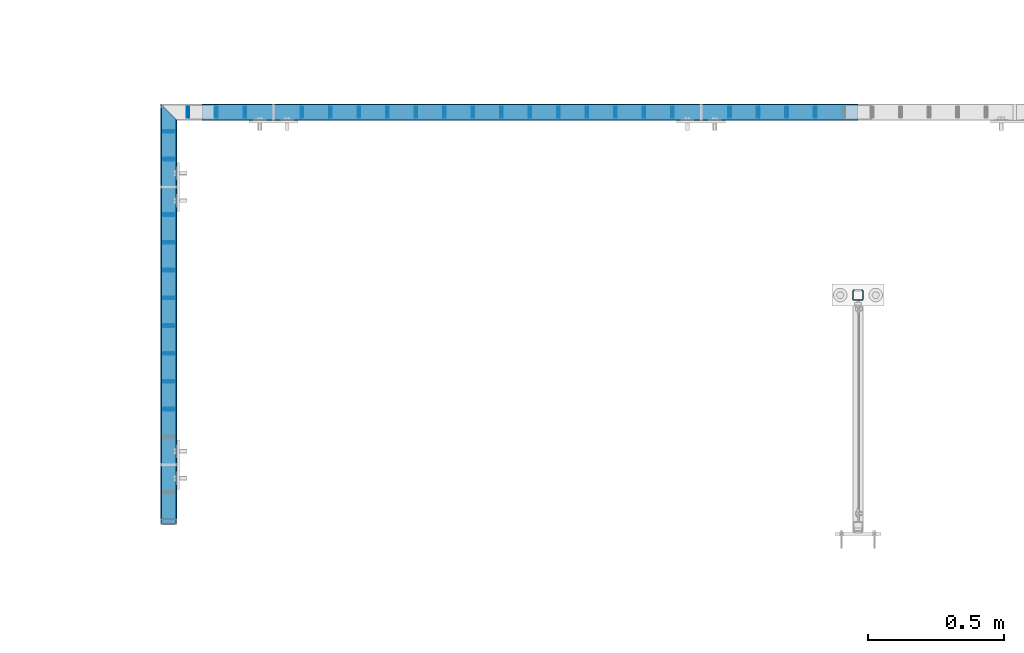
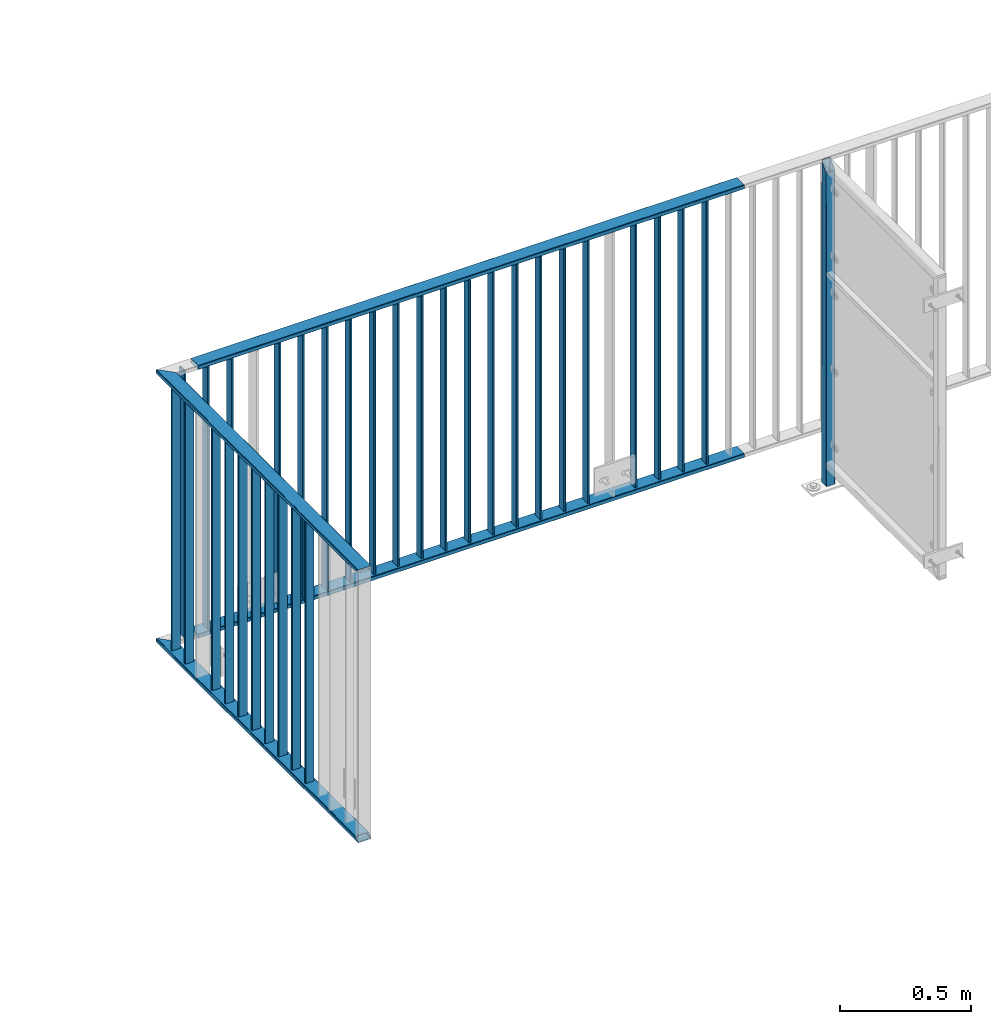
# One storey, part 34 of 156: 36 beams, 3 elements without a shape of their own.
"""IFC2X3 building model written with IfcOpenShell, lengths in millimetres."""

from ifc_helpers import new_model, si_unit, frame, origin_with_axes, origin_2d_with_axis, place, context, subcontext, project, spatial, hollow_rectangle, extrude, clip, halfspace, material, type_object, element, aggregate, save


model = new_model("IFC2X3")

# Units and contexts
model_context = context("Model", 3, precision=1e-05, world=origin_with_axes())
body_context = subcontext(model_context, "Body", "Model", "MODEL_VIEW")
ifc_project = project(units=[si_unit("LENGTHUNIT", "METRE", prefix="MILLI"), si_unit("AREAUNIT", "SQUARE_METRE"), si_unit("VOLUMEUNIT", "CUBIC_METRE"), si_unit("MASSUNIT", "GRAM", prefix="KILO"), si_unit("TIMEUNIT", "SECOND"), si_unit("PLANEANGLEUNIT", "RADIAN"), si_unit("SOLIDANGLEUNIT", "STERADIAN"), si_unit("THERMODYNAMICTEMPERATUREUNIT", "DEGREE_CELSIUS"), si_unit("LUMINOUSINTENSITYUNIT", "LUMEN")], contexts=[model_context])

# Site, building, storey
site_placement = place(None, origin_with_axes())
site = spatial("IfcSite", under=ifc_project, at=site_placement, CompositionType="ELEMENT")
building_placement = place(site_placement, origin_with_axes())
building = spatial("IfcBuilding", under=site, at=building_placement, Name="Undefined", CompositionType="ELEMENT")
storey_placement = place(building_placement, origin_with_axes())
storey = spatial("IfcBuildingStorey", under=building, at=storey_placement, Name="Undefined", CompositionType="ELEMENT", Elevation=0.0)

# Assembly, beam
assembly_1_placement = place(storey_placement, origin_with_axes())
assembly_1 = element("IfcElementAssembly", 1, at=assembly_1_placement, inside=storey, AssemblyPlace="NOTDEFINED", PredefinedType="RIGID_FRAME")
ifc_material = material(Name="STEEL/S235JR")
beam_type_1 = type_object("IfcBeamType", Name="K60/20/2", PredefinedType="NOTDEFINED")
beam_1_placement = place(assembly_1_placement, frame((43599.9526043701, 21657.990447998, 2740.0), z_axis=(0.0, -1.0, 0.0), x_axis=(-1.0, 0.0, 0.0)))
beam_1 = element("IfcBeam", 2, at=beam_1_placement, type_object=beam_type_1, material=ifc_material, ObjectType="K60/20/2", context=body_context, shape_type="SweptSolid", body=[
    extrude(hollow_rectangle(XDim=20.0, YDim=60.0, WallThickness=2.0, InnerFilletRadius=2.0, OuterFilletRadius=4.0, at=origin_2d_with_axis()), frame((2402.81, 0.0, 0.0), z_axis=(-1.0, 0.0, 0.0), x_axis=(0.0, -1.0, 0.0)), (0.0, 0.0, 1.0), 2402.81),
])

assembly_2_placement = place(storey_placement, origin_with_axes())
assembly_2 = element("IfcElementAssembly", 3, at=assembly_2_placement, inside=storey, AssemblyPlace="NOTDEFINED", PredefinedType="RIGID_FRAME")
beam_2_placement = place(assembly_2_placement, frame((41074.9973602295, 21631.4392182553, 2740.0), z_axis=(1.0, 0.0, 0.0), x_axis=(0.0, -1.0, 0.0)))
beam_2 = element("IfcBeam", 4, at=beam_2_placement, type_object=beam_type_1, material=ifc_material, ObjectType="K60/20/2", context=body_context, shape_type="Clipping", body=[
    clip(clip(extrude(hollow_rectangle(XDim=20.0, YDim=60.0, WallThickness=2.0, InnerFilletRadius=2.0, OuterFilletRadius=4.0, at=origin_2d_with_axis()), frame((1513.83911766303, 0.0, 0.0), z_axis=(-1.0, 0.0, 0.0), x_axis=(0.0, -1.0, 0.0)), (0.0, 0.0, 1.0), 1580.79), halfspace(frame((1483.43911766303, 10.0, 0.002166748046875), z_axis=(-0.707106781186548, 0.707106781186548, 0.0), x_axis=(0.0, 0.0, 1.0)), True)), halfspace(frame((3.44877025730966, 0.0, 30.0), z_axis=(-0.707106781186548, 0.0, 0.707106781186548), x_axis=(0.0, -1.0, 0.0)), False)),
])

# Beam
beam_3_placement = place(assembly_1_placement, frame((43599.9526043701, 21657.990447998, 3990.0), z_axis=(0.0, -1.0, 0.0), x_axis=(-1.0, 0.0, 0.0)))
beam_3 = element("IfcBeam", 5, at=beam_3_placement, type_object=beam_type_1, material=ifc_material, ObjectType="K60/20/2", context=body_context, shape_type="SweptSolid", body=[
    extrude(hollow_rectangle(XDim=20.0, YDim=60.0, WallThickness=2.0, InnerFilletRadius=2.0, OuterFilletRadius=4.0, at=origin_2d_with_axis()), frame((2402.81, 0.0, 0.0), z_axis=(-1.0, 0.0, 0.0), x_axis=(0.0, -1.0, 0.0)), (0.0, 0.0, 1.0), 2402.81),
])

beam_4_placement = place(assembly_2_placement, frame((41074.9973602295, 21631.4392182553, 3990.0), z_axis=(1.0, 0.0, 0.0), x_axis=(0.0, -1.0, 0.0)))
beam_4 = element("IfcBeam", 6, at=beam_4_placement, type_object=beam_type_1, material=ifc_material, ObjectType="K60/20/2", context=body_context, shape_type="Clipping", body=[
    clip(clip(extrude(hollow_rectangle(XDim=20.0, YDim=60.0, WallThickness=2.0, InnerFilletRadius=2.0, OuterFilletRadius=4.0, at=origin_2d_with_axis()), frame((1513.83911766303, 0.0, 0.0), z_axis=(-1.0, 0.0, 0.0), x_axis=(0.0, -1.0, 0.0)), (0.0, 0.0, 1.0), 1580.79), halfspace(frame((1463.43911766303, 10.0, 0.002166748046875), z_axis=(-0.707106781186548, -0.707106781186548, 0.0), x_axis=(0.0, 0.0, 1.0)), True)), halfspace(frame((-56.5512297426903, 0.0, -30.0), z_axis=(0.707106781186548, 0.0, -0.707106781186548), x_axis=(0.0, -1.0, 0.0)), True)),
])

beam_type_2 = type_object("IfcBeamType", Name="K40/10/1.5", PredefinedType="NOTDEFINED")
beam_5_placement = place(assembly_2_placement, frame((41074.9973679284, 20570.1892182564, 3980.00000000003), z_axis=(1.0, 0.0, 0.0), x_axis=(0.0, 0.0, -1.0)))
beam_5 = element("IfcBeam", 7, at=beam_5_placement, type_object=beam_type_2, material=ifc_material, ObjectType="K40/10/1.5", context=body_context, shape_type="Clipping", body=[
    clip(clip(extrude(hollow_rectangle(XDim=10.0, YDim=40.0, WallThickness=1.5, InnerFilletRadius=1.5, OuterFilletRadius=3.0, at=origin_2d_with_axis()), frame((1237.00000000003, 0.0, 0.0), z_axis=(-1.0, 0.0, 0.0), x_axis=(0.0, -1.0, 0.0)), (0.0, 0.0, 1.0), 1244.0), halfspace(frame((1237.00000000003, 3.2449841921989, 46.4665039507236), z_axis=(1.0, 0.0, 0.0), x_axis=(0.0, -0.754414263122933, -0.656398598106883)), False)), halfspace(frame((-6.99999999997453, -3.24498419219526, 46.4665039507308), z_axis=(-1.0, 0.0, 0.0), x_axis=(0.0, 0.75441426312288, -0.656398598106944)), False)),
])

beam_6_placement = place(assembly_2_placement, frame((41074.9973679284, 20671.9692182564, 3980.00000000003), z_axis=(1.0, 0.0, 0.0), x_axis=(0.0, 0.0, -1.0)))
beam_6 = element("IfcBeam", 8, at=beam_6_placement, type_object=beam_type_2, material=ifc_material, ObjectType="K40/10/1.5", context=body_context, shape_type="Clipping", body=[
    clip(clip(extrude(hollow_rectangle(XDim=10.0, YDim=40.0, WallThickness=1.5, InnerFilletRadius=1.5, OuterFilletRadius=3.0, at=origin_2d_with_axis()), frame((1237.00000000003, 0.0, 0.0), z_axis=(-1.0, 0.0, 0.0), x_axis=(0.0, -1.0, 0.0)), (0.0, 0.0, 1.0), 1244.0), halfspace(frame((1237.00000000003, 3.2449841921989, 46.4665039507236), z_axis=(1.0, 0.0, 0.0), x_axis=(0.0, -0.754414263122933, -0.656398598106883)), False)), halfspace(frame((-6.99999999997453, -3.24498419219526, 46.4665039507308), z_axis=(-1.0, 0.0, 0.0), x_axis=(0.0, 0.75441426312288, -0.656398598106944)), False)),
])

beam_7_placement = place(assembly_2_placement, frame((41074.9973679284, 20773.7492182564, 3980.00000000003), z_axis=(1.0, 0.0, 0.0), x_axis=(0.0, 0.0, -1.0)))
beam_7 = element("IfcBeam", 9, at=beam_7_placement, type_object=beam_type_2, material=ifc_material, ObjectType="K40/10/1.5", context=body_context, shape_type="Clipping", body=[
    clip(clip(extrude(hollow_rectangle(XDim=10.0, YDim=40.0, WallThickness=1.5, InnerFilletRadius=1.5, OuterFilletRadius=3.0, at=origin_2d_with_axis()), frame((1237.00000000003, 0.0, 0.0), z_axis=(-1.0, 0.0, 0.0), x_axis=(0.0, -1.0, 0.0)), (0.0, 0.0, 1.0), 1244.0), halfspace(frame((1237.00000000003, 3.2449841921989, 46.4665039507236), z_axis=(1.0, 0.0, 0.0), x_axis=(0.0, -0.754414263122933, -0.656398598106883)), False)), halfspace(frame((-6.99999999997453, -3.24498419219526, 46.4665039507308), z_axis=(-1.0, 0.0, 0.0), x_axis=(0.0, 0.75441426312288, -0.656398598106944)), False)),
])

beam_8_placement = place(assembly_2_placement, frame((41074.9973679284, 20875.5292182564, 3980.00000000003), z_axis=(1.0, 0.0, 0.0), x_axis=(0.0, 0.0, -1.0)))
beam_8 = element("IfcBeam", 10, at=beam_8_placement, type_object=beam_type_2, material=ifc_material, ObjectType="K40/10/1.5", context=body_context, shape_type="Clipping", body=[
    clip(clip(extrude(hollow_rectangle(XDim=10.0, YDim=40.0, WallThickness=1.5, InnerFilletRadius=1.5, OuterFilletRadius=3.0, at=origin_2d_with_axis()), frame((1237.00000000003, 0.0, 0.0), z_axis=(-1.0, 0.0, 0.0), x_axis=(0.0, -1.0, 0.0)), (0.0, 0.0, 1.0), 1244.0), halfspace(frame((1237.00000000003, 3.2449841921989, 46.4665039507236), z_axis=(1.0, 0.0, 0.0), x_axis=(0.0, -0.754414263122933, -0.656398598106883)), False)), halfspace(frame((-6.99999999997453, -3.24498419219526, 46.4665039507308), z_axis=(-1.0, 0.0, 0.0), x_axis=(0.0, 0.75441426312288, -0.656398598106944)), False)),
])

beam_9_placement = place(assembly_2_placement, frame((41074.9973679284, 20977.3092182564, 3980.00000000003), z_axis=(1.0, 0.0, 0.0), x_axis=(0.0, 0.0, -1.0)))
beam_9 = element("IfcBeam", 11, at=beam_9_placement, type_object=beam_type_2, material=ifc_material, ObjectType="K40/10/1.5", context=body_context, shape_type="Clipping", body=[
    clip(clip(extrude(hollow_rectangle(XDim=10.0, YDim=40.0, WallThickness=1.5, InnerFilletRadius=1.5, OuterFilletRadius=3.0, at=origin_2d_with_axis()), frame((1237.00000000003, 0.0, 0.0), z_axis=(-1.0, 0.0, 0.0), x_axis=(0.0, -1.0, 0.0)), (0.0, 0.0, 1.0), 1244.0), halfspace(frame((1237.00000000003, 3.2449841921989, 46.4665039507236), z_axis=(1.0, 0.0, 0.0), x_axis=(0.0, -0.754414263122933, -0.656398598106883)), False)), halfspace(frame((-6.99999999997453, -3.24498419219526, 46.4665039507308), z_axis=(-1.0, 0.0, 0.0), x_axis=(0.0, 0.75441426312288, -0.656398598106944)), False)),
])

beam_10_placement = place(assembly_2_placement, frame((41074.9973679284, 21079.0892182564, 3980.00000000003), z_axis=(1.0, 0.0, 0.0), x_axis=(0.0, 0.0, -1.0)))
beam_10 = element("IfcBeam", 12, at=beam_10_placement, type_object=beam_type_2, material=ifc_material, ObjectType="K40/10/1.5", context=body_context, shape_type="Clipping", body=[
    clip(clip(extrude(hollow_rectangle(XDim=10.0, YDim=40.0, WallThickness=1.5, InnerFilletRadius=1.5, OuterFilletRadius=3.0, at=origin_2d_with_axis()), frame((1237.00000000003, 0.0, 0.0), z_axis=(-1.0, 0.0, 0.0), x_axis=(0.0, -1.0, 0.0)), (0.0, 0.0, 1.0), 1244.0), halfspace(frame((1237.00000000003, 3.2449841921989, 46.4665039507236), z_axis=(1.0, 0.0, 0.0), x_axis=(0.0, -0.754414263122933, -0.656398598106883)), False)), halfspace(frame((-6.99999999997453, -3.24498419219526, 46.4665039507308), z_axis=(-1.0, 0.0, 0.0), x_axis=(0.0, 0.75441426312288, -0.656398598106944)), False)),
])

beam_11_placement = place(assembly_2_placement, frame((41074.9973679284, 21180.8692182564, 3980.00000000003), z_axis=(1.0, 0.0, 0.0), x_axis=(0.0, 0.0, -1.0)))
beam_11 = element("IfcBeam", 13, at=beam_11_placement, type_object=beam_type_2, material=ifc_material, ObjectType="K40/10/1.5", context=body_context, shape_type="Clipping", body=[
    clip(clip(extrude(hollow_rectangle(XDim=10.0, YDim=40.0, WallThickness=1.5, InnerFilletRadius=1.5, OuterFilletRadius=3.0, at=origin_2d_with_axis()), frame((1237.00000000003, 0.0, 0.0), z_axis=(-1.0, 0.0, 0.0), x_axis=(0.0, -1.0, 0.0)), (0.0, 0.0, 1.0), 1244.0), halfspace(frame((1237.00000000003, 3.2449841921989, 46.4665039507236), z_axis=(1.0, 0.0, 0.0), x_axis=(0.0, -0.754414263122933, -0.656398598106883)), False)), halfspace(frame((-6.99999999997453, -3.24498419219526, 46.4665039507308), z_axis=(-1.0, 0.0, 0.0), x_axis=(0.0, 0.75441426312288, -0.656398598106944)), False)),
])

beam_12_placement = place(assembly_2_placement, frame((41074.9973679284, 21282.6492182564, 3980.00000000003), z_axis=(1.0, 0.0, 0.0), x_axis=(0.0, 0.0, -1.0)))
beam_12 = element("IfcBeam", 14, at=beam_12_placement, type_object=beam_type_2, material=ifc_material, ObjectType="K40/10/1.5", context=body_context, shape_type="Clipping", body=[
    clip(clip(extrude(hollow_rectangle(XDim=10.0, YDim=40.0, WallThickness=1.5, InnerFilletRadius=1.5, OuterFilletRadius=3.0, at=origin_2d_with_axis()), frame((1237.00000000003, 0.0, 0.0), z_axis=(-1.0, 0.0, 0.0), x_axis=(0.0, -1.0, 0.0)), (0.0, 0.0, 1.0), 1244.0), halfspace(frame((1237.00000000003, 3.2449841921989, 46.4665039507236), z_axis=(1.0, 0.0, 0.0), x_axis=(0.0, -0.754414263122933, -0.656398598106883)), False)), halfspace(frame((-6.99999999997453, -3.24498419219526, 46.4665039507308), z_axis=(-1.0, 0.0, 0.0), x_axis=(0.0, 0.75441426312288, -0.656398598106944)), False)),
])

beam_13_placement = place(assembly_1_placement, frame((41353.8476043701, 21657.990447998, 3980.00000000003), z_axis=(0.0, -1.0, 0.0), x_axis=(0.0, 0.0, -1.0)))
beam_13 = element("IfcBeam", 15, at=beam_13_placement, type_object=beam_type_2, material=ifc_material, ObjectType="K40/10/1.5", context=body_context, shape_type="Clipping", body=[
    clip(clip(extrude(hollow_rectangle(XDim=10.0, YDim=40.0, WallThickness=1.5, InnerFilletRadius=1.5, OuterFilletRadius=3.0, at=origin_2d_with_axis()), frame((1237.00000000003, 0.0, 0.0), z_axis=(-1.0, 0.0, 0.0), x_axis=(0.0, -1.0, 0.0)), (0.0, 0.0, 1.0), 1244.0), halfspace(frame((1237.00000000003, 4.34248751949781, 47.3810900558092), z_axis=(1.0, 0.0, 0.0), x_axis=(0.0, -0.768354814194188, -0.640024124158313)), False)), halfspace(frame((-6.99999999997453, -4.34248751950508, 47.3810900558092), z_axis=(-1.0, 0.0, 0.0), x_axis=(0.0, 0.7683548141934, -0.640024124159258)), False)),
])

beam_14_placement = place(assembly_1_placement, frame((42920.8976043701, 21657.990447998, 3980.00000000003), z_axis=(0.0, -1.0, 0.0), x_axis=(0.0, 0.0, -1.0)))
beam_14 = element("IfcBeam", 16, at=beam_14_placement, type_object=beam_type_2, material=ifc_material, ObjectType="K40/10/1.5", context=body_context, shape_type="Clipping", body=[
    clip(clip(extrude(hollow_rectangle(XDim=10.0, YDim=40.0, WallThickness=1.5, InnerFilletRadius=1.5, OuterFilletRadius=3.0, at=origin_2d_with_axis()), frame((1237.00000000003, 0.0, 0.0), z_axis=(-1.0, 0.0, 0.0), x_axis=(0.0, -1.0, 0.0)), (0.0, 0.0, 1.0), 1244.0), halfspace(frame((1237.00000000003, 4.34248751949781, 47.3810900558092), z_axis=(1.0, 0.0, 0.0), x_axis=(0.0, -0.768354814194188, -0.640024124158313)), False)), halfspace(frame((-6.99999999997453, -4.34248751950508, 47.3810900558092), z_axis=(-1.0, 0.0, 0.0), x_axis=(0.0, 0.7683548141934, -0.640024124159258)), False)),
])

beam_15_placement = place(assembly_1_placement, frame((41249.3776043701, 21657.990447998, 3980.00000000003), z_axis=(0.0, -1.0, 0.0), x_axis=(0.0, 0.0, -1.0)))
beam_15 = element("IfcBeam", 17, at=beam_15_placement, type_object=beam_type_2, material=ifc_material, ObjectType="K40/10/1.5", context=body_context, shape_type="Clipping", body=[
    clip(clip(extrude(hollow_rectangle(XDim=10.0, YDim=40.0, WallThickness=1.5, InnerFilletRadius=1.5, OuterFilletRadius=3.0, at=origin_2d_with_axis()), frame((1237.00000000003, 0.0, 0.0), z_axis=(-1.0, 0.0, 0.0), x_axis=(0.0, -1.0, 0.0)), (0.0, 0.0, 1.0), 1244.0), halfspace(frame((1237.00000000003, 4.34248751949781, 47.3810900558092), z_axis=(1.0, 0.0, 0.0), x_axis=(0.0, -0.763991285051099, -0.645226562043109)), False)), halfspace(frame((-6.99999999997453, -4.34248751950508, 47.3810900558092), z_axis=(-1.0, 0.0, 0.0), x_axis=(0.0, 0.763991285051099, -0.645226562043109)), False)),
])

beam_16_placement = place(assembly_1_placement, frame((41562.7876043701, 21657.990447998, 3980.00000000003), z_axis=(0.0, -1.0, 0.0), x_axis=(0.0, 0.0, -1.0)))
beam_16 = element("IfcBeam", 18, at=beam_16_placement, type_object=beam_type_2, material=ifc_material, ObjectType="K40/10/1.5", context=body_context, shape_type="Clipping", body=[
    clip(clip(extrude(hollow_rectangle(XDim=10.0, YDim=40.0, WallThickness=1.5, InnerFilletRadius=1.5, OuterFilletRadius=3.0, at=origin_2d_with_axis()), frame((1237.00000000003, 0.0, 0.0), z_axis=(-1.0, 0.0, 0.0), x_axis=(0.0, -1.0, 0.0)), (0.0, 0.0, 1.0), 1244.0), halfspace(frame((1237.00000000003, 4.34248751949781, 47.3810900558092), z_axis=(1.0, 0.0, 0.0), x_axis=(0.0, -0.768354814194188, -0.640024124158313)), False)), halfspace(frame((-6.99999999997453, -4.34248751950508, 47.3810900558092), z_axis=(-1.0, 0.0, 0.0), x_axis=(0.0, 0.7683548141934, -0.640024124159258)), False)),
])

beam_17_placement = place(assembly_1_placement, frame((41667.2576043701, 21657.990447998, 3980.00000000003), z_axis=(0.0, -1.0, 0.0), x_axis=(0.0, 0.0, -1.0)))
beam_17 = element("IfcBeam", 19, at=beam_17_placement, type_object=beam_type_2, material=ifc_material, ObjectType="K40/10/1.5", context=body_context, shape_type="Clipping", body=[
    clip(clip(extrude(hollow_rectangle(XDim=10.0, YDim=40.0, WallThickness=1.5, InnerFilletRadius=1.5, OuterFilletRadius=3.0, at=origin_2d_with_axis()), frame((1237.00000000003, 0.0, 0.0), z_axis=(-1.0, 0.0, 0.0), x_axis=(0.0, -1.0, 0.0)), (0.0, 0.0, 1.0), 1244.0), halfspace(frame((1237.00000000003, 4.34248751949781, 47.3810900558092), z_axis=(1.0, 0.0, 0.0), x_axis=(0.0, -0.768354814194188, -0.640024124158313)), False)), halfspace(frame((-6.99999999997453, -4.34248751950508, 47.3810900558092), z_axis=(-1.0, 0.0, 0.0), x_axis=(0.0, 0.7683548141934, -0.640024124159258)), False)),
])

beam_18_placement = place(assembly_1_placement, frame((41771.7276043701, 21657.990447998, 3980.00000000003), z_axis=(0.0, -1.0, 0.0), x_axis=(0.0, 0.0, -1.0)))
beam_18 = element("IfcBeam", 20, at=beam_18_placement, type_object=beam_type_2, material=ifc_material, ObjectType="K40/10/1.5", context=body_context, shape_type="Clipping", body=[
    clip(clip(extrude(hollow_rectangle(XDim=10.0, YDim=40.0, WallThickness=1.5, InnerFilletRadius=1.5, OuterFilletRadius=3.0, at=origin_2d_with_axis()), frame((1237.00000000003, 0.0, 0.0), z_axis=(-1.0, 0.0, 0.0), x_axis=(0.0, -1.0, 0.0)), (0.0, 0.0, 1.0), 1244.0), halfspace(frame((1237.00000000003, 4.34248751949781, 47.3810900558092), z_axis=(1.0, 0.0, 0.0), x_axis=(0.0, -0.768354814194188, -0.640024124158313)), False)), halfspace(frame((-6.99999999997453, -4.34248751950508, 47.3810900558092), z_axis=(-1.0, 0.0, 0.0), x_axis=(0.0, 0.7683548141934, -0.640024124159258)), False)),
])

beam_19_placement = place(assembly_1_placement, frame((41876.1976043701, 21657.990447998, 3980.00000000003), z_axis=(0.0, -1.0, 0.0), x_axis=(0.0, 0.0, -1.0)))
beam_19 = element("IfcBeam", 21, at=beam_19_placement, type_object=beam_type_2, material=ifc_material, ObjectType="K40/10/1.5", context=body_context, shape_type="Clipping", body=[
    clip(clip(extrude(hollow_rectangle(XDim=10.0, YDim=40.0, WallThickness=1.5, InnerFilletRadius=1.5, OuterFilletRadius=3.0, at=origin_2d_with_axis()), frame((1237.00000000003, 0.0, 0.0), z_axis=(-1.0, 0.0, 0.0), x_axis=(0.0, -1.0, 0.0)), (0.0, 0.0, 1.0), 1244.0), halfspace(frame((1237.00000000003, 4.34248751949781, 47.3810900558092), z_axis=(1.0, 0.0, 0.0), x_axis=(0.0, -0.768354814194188, -0.640024124158313)), False)), halfspace(frame((-6.99999999997453, -4.34248751950508, 47.3810900558092), z_axis=(-1.0, 0.0, 0.0), x_axis=(0.0, 0.7683548141934, -0.640024124159258)), False)),
])

beam_20_placement = place(assembly_1_placement, frame((41980.6676043701, 21657.990447998, 3980.00000000003), z_axis=(0.0, -1.0, 0.0), x_axis=(0.0, 0.0, -1.0)))
beam_20 = element("IfcBeam", 22, at=beam_20_placement, type_object=beam_type_2, material=ifc_material, ObjectType="K40/10/1.5", context=body_context, shape_type="Clipping", body=[
    clip(clip(extrude(hollow_rectangle(XDim=10.0, YDim=40.0, WallThickness=1.5, InnerFilletRadius=1.5, OuterFilletRadius=3.0, at=origin_2d_with_axis()), frame((1237.00000000003, 0.0, 0.0), z_axis=(-1.0, 0.0, 0.0), x_axis=(0.0, -1.0, 0.0)), (0.0, 0.0, 1.0), 1244.0), halfspace(frame((1237.00000000003, 4.34248751949781, 47.3810900558092), z_axis=(1.0, 0.0, 0.0), x_axis=(0.0, -0.768354814194188, -0.640024124158313)), False)), halfspace(frame((-6.99999999997453, -4.34248751950508, 47.3810900558092), z_axis=(-1.0, 0.0, 0.0), x_axis=(0.0, 0.7683548141934, -0.640024124159258)), False)),
])

beam_21_placement = place(assembly_1_placement, frame((42085.1376043701, 21657.990447998, 3980.00000000003), z_axis=(0.0, -1.0, 0.0), x_axis=(0.0, 0.0, -1.0)))
beam_21 = element("IfcBeam", 23, at=beam_21_placement, type_object=beam_type_2, material=ifc_material, ObjectType="K40/10/1.5", context=body_context, shape_type="Clipping", body=[
    clip(clip(extrude(hollow_rectangle(XDim=10.0, YDim=40.0, WallThickness=1.5, InnerFilletRadius=1.5, OuterFilletRadius=3.0, at=origin_2d_with_axis()), frame((1237.00000000003, 0.0, 0.0), z_axis=(-1.0, 0.0, 0.0), x_axis=(0.0, -1.0, 0.0)), (0.0, 0.0, 1.0), 1244.0), halfspace(frame((1237.00000000003, 4.34248751949781, 47.3810900558092), z_axis=(1.0, 0.0, 0.0), x_axis=(0.0, -0.768354814194188, -0.640024124158313)), False)), halfspace(frame((-6.99999999997453, -4.34248751950508, 47.3810900558092), z_axis=(-1.0, 0.0, 0.0), x_axis=(0.0, 0.7683548141934, -0.640024124159258)), False)),
])

beam_22_placement = place(assembly_1_placement, frame((42189.6076043701, 21657.990447998, 3980.00000000003), z_axis=(0.0, -1.0, 0.0), x_axis=(0.0, 0.0, -1.0)))
beam_22 = element("IfcBeam", 24, at=beam_22_placement, type_object=beam_type_2, material=ifc_material, ObjectType="K40/10/1.5", context=body_context, shape_type="Clipping", body=[
    clip(clip(extrude(hollow_rectangle(XDim=10.0, YDim=40.0, WallThickness=1.5, InnerFilletRadius=1.5, OuterFilletRadius=3.0, at=origin_2d_with_axis()), frame((1237.00000000003, 0.0, 0.0), z_axis=(-1.0, 0.0, 0.0), x_axis=(0.0, -1.0, 0.0)), (0.0, 0.0, 1.0), 1244.0), halfspace(frame((1237.00000000003, 4.34248751949781, 47.3810900558092), z_axis=(1.0, 0.0, 0.0), x_axis=(0.0, -0.768354814194188, -0.640024124158313)), False)), halfspace(frame((-6.99999999997453, -4.34248751950508, 47.3810900558092), z_axis=(-1.0, 0.0, 0.0), x_axis=(0.0, 0.7683548141934, -0.640024124159258)), False)),
])

beam_23_placement = place(assembly_1_placement, frame((42294.0776043701, 21657.990447998, 3980.00000000003), z_axis=(0.0, -1.0, 0.0), x_axis=(0.0, 0.0, -1.0)))
beam_23 = element("IfcBeam", 25, at=beam_23_placement, type_object=beam_type_2, material=ifc_material, ObjectType="K40/10/1.5", context=body_context, shape_type="Clipping", body=[
    clip(clip(extrude(hollow_rectangle(XDim=10.0, YDim=40.0, WallThickness=1.5, InnerFilletRadius=1.5, OuterFilletRadius=3.0, at=origin_2d_with_axis()), frame((1237.00000000003, 0.0, 0.0), z_axis=(-1.0, 0.0, 0.0), x_axis=(0.0, -1.0, 0.0)), (0.0, 0.0, 1.0), 1244.0), halfspace(frame((1237.00000000003, 4.34248751949781, 47.3810900558092), z_axis=(1.0, 0.0, 0.0), x_axis=(0.0, -0.768354814194188, -0.640024124158313)), False)), halfspace(frame((-6.99999999997453, -4.34248751950508, 47.3810900558092), z_axis=(-1.0, 0.0, 0.0), x_axis=(0.0, 0.7683548141934, -0.640024124159258)), False)),
])

beam_24_placement = place(assembly_1_placement, frame((42398.5476043701, 21657.990447998, 3980.00000000003), z_axis=(0.0, -1.0, 0.0), x_axis=(0.0, 0.0, -1.0)))
beam_24 = element("IfcBeam", 26, at=beam_24_placement, type_object=beam_type_2, material=ifc_material, ObjectType="K40/10/1.5", context=body_context, shape_type="Clipping", body=[
    clip(clip(extrude(hollow_rectangle(XDim=10.0, YDim=40.0, WallThickness=1.5, InnerFilletRadius=1.5, OuterFilletRadius=3.0, at=origin_2d_with_axis()), frame((1237.00000000003, 0.0, 0.0), z_axis=(-1.0, 0.0, 0.0), x_axis=(0.0, -1.0, 0.0)), (0.0, 0.0, 1.0), 1244.0), halfspace(frame((1237.00000000003, 4.34248751949781, 47.3810900558092), z_axis=(1.0, 0.0, 0.0), x_axis=(0.0, -0.768354814194188, -0.640024124158313)), False)), halfspace(frame((-6.99999999997453, -4.34248751950508, 47.3810900558092), z_axis=(-1.0, 0.0, 0.0), x_axis=(0.0, 0.7683548141934, -0.640024124159258)), False)),
])

beam_25_placement = place(assembly_1_placement, frame((42503.0176043701, 21657.990447998, 3980.00000000003), z_axis=(0.0, -1.0, 0.0), x_axis=(0.0, 0.0, -1.0)))
beam_25 = element("IfcBeam", 27, at=beam_25_placement, type_object=beam_type_2, material=ifc_material, ObjectType="K40/10/1.5", context=body_context, shape_type="Clipping", body=[
    clip(clip(extrude(hollow_rectangle(XDim=10.0, YDim=40.0, WallThickness=1.5, InnerFilletRadius=1.5, OuterFilletRadius=3.0, at=origin_2d_with_axis()), frame((1237.00000000003, 0.0, 0.0), z_axis=(-1.0, 0.0, 0.0), x_axis=(0.0, -1.0, 0.0)), (0.0, 0.0, 1.0), 1244.0), halfspace(frame((1237.00000000003, 4.34248751949781, 47.3810900558092), z_axis=(1.0, 0.0, 0.0), x_axis=(0.0, -0.768354814194188, -0.640024124158313)), False)), halfspace(frame((-6.99999999997453, -4.34248751950508, 47.3810900558092), z_axis=(-1.0, 0.0, 0.0), x_axis=(0.0, 0.7683548141934, -0.640024124159258)), False)),
])

beam_26_placement = place(assembly_1_placement, frame((42607.4876043701, 21657.990447998, 3980.00000000003), z_axis=(0.0, -1.0, 0.0), x_axis=(0.0, 0.0, -1.0)))
beam_26 = element("IfcBeam", 28, at=beam_26_placement, type_object=beam_type_2, material=ifc_material, ObjectType="K40/10/1.5", context=body_context, shape_type="Clipping", body=[
    clip(clip(extrude(hollow_rectangle(XDim=10.0, YDim=40.0, WallThickness=1.5, InnerFilletRadius=1.5, OuterFilletRadius=3.0, at=origin_2d_with_axis()), frame((1237.00000000003, 0.0, 0.0), z_axis=(-1.0, 0.0, 0.0), x_axis=(0.0, -1.0, 0.0)), (0.0, 0.0, 1.0), 1244.0), halfspace(frame((1237.00000000003, 4.34248751949781, 47.3810900558092), z_axis=(1.0, 0.0, 0.0), x_axis=(0.0, -0.768354814194188, -0.640024124158313)), False)), halfspace(frame((-6.99999999997453, -4.34248751950508, 47.3810900558092), z_axis=(-1.0, 0.0, 0.0), x_axis=(0.0, 0.7683548141934, -0.640024124159258)), False)),
])

beam_27_placement = place(assembly_1_placement, frame((42711.9576043701, 21657.990447998, 3980.00000000003), z_axis=(0.0, -1.0, 0.0), x_axis=(0.0, 0.0, -1.0)))
beam_27 = element("IfcBeam", 29, at=beam_27_placement, type_object=beam_type_2, material=ifc_material, ObjectType="K40/10/1.5", context=body_context, shape_type="Clipping", body=[
    clip(clip(extrude(hollow_rectangle(XDim=10.0, YDim=40.0, WallThickness=1.5, InnerFilletRadius=1.5, OuterFilletRadius=3.0, at=origin_2d_with_axis()), frame((1237.00000000003, 0.0, 0.0), z_axis=(-1.0, 0.0, 0.0), x_axis=(0.0, -1.0, 0.0)), (0.0, 0.0, 1.0), 1244.0), halfspace(frame((1237.00000000003, 4.34248751949781, 47.3810900558092), z_axis=(1.0, 0.0, 0.0), x_axis=(0.0, -0.768354814194188, -0.640024124158313)), False)), halfspace(frame((-6.99999999997453, -4.34248751950508, 47.3810900558092), z_axis=(-1.0, 0.0, 0.0), x_axis=(0.0, 0.7683548141934, -0.640024124159258)), False)),
])

beam_28_placement = place(assembly_1_placement, frame((42816.4276043701, 21657.990447998, 3980.00000000003), z_axis=(0.0, -1.0, 0.0), x_axis=(0.0, 0.0, -1.0)))
beam_28 = element("IfcBeam", 30, at=beam_28_placement, type_object=beam_type_2, material=ifc_material, ObjectType="K40/10/1.5", context=body_context, shape_type="Clipping", body=[
    clip(clip(extrude(hollow_rectangle(XDim=10.0, YDim=40.0, WallThickness=1.5, InnerFilletRadius=1.5, OuterFilletRadius=3.0, at=origin_2d_with_axis()), frame((1237.00000000003, 0.0, 0.0), z_axis=(-1.0, 0.0, 0.0), x_axis=(0.0, -1.0, 0.0)), (0.0, 0.0, 1.0), 1244.0), halfspace(frame((1237.00000000003, 4.34248751949781, 47.3810900558092), z_axis=(1.0, 0.0, 0.0), x_axis=(0.0, -0.768354814194188, -0.640024124158313)), False)), halfspace(frame((-6.99999999997453, -4.34248751950508, 47.3810900558092), z_axis=(-1.0, 0.0, 0.0), x_axis=(0.0, 0.7683548141934, -0.640024124159258)), False)),
])

beam_29_placement = place(assembly_1_placement, frame((43129.8376043701, 21657.990447998, 3980.00000000003), z_axis=(0.0, -1.0, 0.0), x_axis=(0.0, 0.0, -1.0)))
beam_29 = element("IfcBeam", 31, at=beam_29_placement, type_object=beam_type_2, material=ifc_material, ObjectType="K40/10/1.5", context=body_context, shape_type="Clipping", body=[
    clip(clip(extrude(hollow_rectangle(XDim=10.0, YDim=40.0, WallThickness=1.5, InnerFilletRadius=1.5, OuterFilletRadius=3.0, at=origin_2d_with_axis()), frame((1237.00000000003, 0.0, 0.0), z_axis=(-1.0, 0.0, 0.0), x_axis=(0.0, -1.0, 0.0)), (0.0, 0.0, 1.0), 1244.0), halfspace(frame((1237.00000000003, 4.34248751949781, 47.3810900558092), z_axis=(1.0, 0.0, 0.0), x_axis=(0.0, -0.768354814194188, -0.640024124158313)), False)), halfspace(frame((-6.99999999997453, -4.34248751950508, 47.3810900558092), z_axis=(-1.0, 0.0, 0.0), x_axis=(0.0, 0.7683548141934, -0.640024124159258)), False)),
])

beam_30_placement = place(assembly_1_placement, frame((43234.3076043701, 21657.990447998, 3980.00000000003), z_axis=(0.0, -1.0, 0.0), x_axis=(0.0, 0.0, -1.0)))
beam_30 = element("IfcBeam", 32, at=beam_30_placement, type_object=beam_type_2, material=ifc_material, ObjectType="K40/10/1.5", context=body_context, shape_type="Clipping", body=[
    clip(clip(extrude(hollow_rectangle(XDim=10.0, YDim=40.0, WallThickness=1.5, InnerFilletRadius=1.5, OuterFilletRadius=3.0, at=origin_2d_with_axis()), frame((1237.00000000003, 0.0, 0.0), z_axis=(-1.0, 0.0, 0.0), x_axis=(0.0, -1.0, 0.0)), (0.0, 0.0, 1.0), 1244.0), halfspace(frame((1237.00000000003, 4.34248751949781, 47.3810900558092), z_axis=(1.0, 0.0, 0.0), x_axis=(0.0, -0.768354814194188, -0.640024124158313)), False)), halfspace(frame((-6.99999999997453, -4.34248751950508, 47.3810900558092), z_axis=(-1.0, 0.0, 0.0), x_axis=(0.0, 0.7683548141934, -0.640024124159258)), False)),
])

beam_31_placement = place(assembly_1_placement, frame((43338.7776043701, 21657.990447998, 3980.00000000003), z_axis=(0.0, -1.0, 0.0), x_axis=(0.0, 0.0, -1.0)))
beam_31 = element("IfcBeam", 33, at=beam_31_placement, type_object=beam_type_2, material=ifc_material, ObjectType="K40/10/1.5", context=body_context, shape_type="Clipping", body=[
    clip(clip(extrude(hollow_rectangle(XDim=10.0, YDim=40.0, WallThickness=1.5, InnerFilletRadius=1.5, OuterFilletRadius=3.0, at=origin_2d_with_axis()), frame((1237.00000000003, 0.0, 0.0), z_axis=(-1.0, 0.0, 0.0), x_axis=(0.0, -1.0, 0.0)), (0.0, 0.0, 1.0), 1244.0), halfspace(frame((1237.00000000003, 4.34248751949781, 47.3810900558092), z_axis=(1.0, 0.0, 0.0), x_axis=(0.0, -0.768354814194188, -0.640024124158313)), False)), halfspace(frame((-6.99999999997453, -4.34248751950508, 47.3810900558092), z_axis=(-1.0, 0.0, 0.0), x_axis=(0.0, 0.7683548141934, -0.640024124159258)), False)),
])

beam_32_placement = place(assembly_1_placement, frame((43443.2476043701, 21657.990447998, 3980.00000000003), z_axis=(0.0, -1.0, 0.0), x_axis=(0.0, 0.0, -1.0)))
beam_32 = element("IfcBeam", 34, at=beam_32_placement, type_object=beam_type_2, material=ifc_material, ObjectType="K40/10/1.5", context=body_context, shape_type="Clipping", body=[
    clip(clip(extrude(hollow_rectangle(XDim=10.0, YDim=40.0, WallThickness=1.5, InnerFilletRadius=1.5, OuterFilletRadius=3.0, at=origin_2d_with_axis()), frame((1237.00000000003, 0.0, 0.0), z_axis=(-1.0, 0.0, 0.0), x_axis=(0.0, -1.0, 0.0)), (0.0, 0.0, 1.0), 1244.0), halfspace(frame((1237.00000000003, 4.34248751949781, 47.3810900558092), z_axis=(1.0, 0.0, 0.0), x_axis=(0.0, -0.768354814194188, -0.640024124158313)), False)), halfspace(frame((-6.99999999997453, -4.34248751950508, 47.3810900558092), z_axis=(-1.0, 0.0, 0.0), x_axis=(0.0, 0.7683548141934, -0.640024124159258)), False)),
])

aggregate(assembly_1, [beam_1, beam_13, beam_14, beam_15, beam_16, beam_17, beam_18, beam_19, beam_20, beam_21, beam_22, beam_23, beam_24, beam_25, beam_26, beam_27, beam_28, beam_29, beam_30, beam_31, beam_32, beam_3])

beam_33_placement = place(assembly_2_placement, frame((41074.9973679284, 21486.2092182564, 3980.00000000003), z_axis=(1.0, 0.0, 0.0), x_axis=(0.0, 0.0, -1.0)))
beam_33 = element("IfcBeam", 35, at=beam_33_placement, type_object=beam_type_2, material=ifc_material, ObjectType="K40/10/1.5", context=body_context, shape_type="Clipping", body=[
    clip(clip(extrude(hollow_rectangle(XDim=10.0, YDim=40.0, WallThickness=1.5, InnerFilletRadius=1.5, OuterFilletRadius=3.0, at=origin_2d_with_axis()), frame((1237.00000000003, 0.0, 0.0), z_axis=(-1.0, 0.0, 0.0), x_axis=(0.0, -1.0, 0.0)), (0.0, 0.0, 1.0), 1244.0), halfspace(frame((1237.00000000003, 2.66359292875859, 45.9820112315028), z_axis=(1.0, 0.0, 0.0), x_axis=(0.0, -0.747680594278991, -0.664058528247785)), False)), halfspace(frame((-6.99999999997453, -2.66359292875859, 45.9820112315028), z_axis=(-1.0, 0.0, 0.0), x_axis=(0.0, 0.747680594279002, -0.664058528247773)), False)),
])

beam_34_placement = place(assembly_2_placement, frame((41144.9970550537, 21657.990447998, 3980.00000000003), z_axis=(0.0, -1.0, 0.0), x_axis=(0.0, 0.0, -1.0)))
beam_34 = element("IfcBeam", 36, at=beam_34_placement, type_object=beam_type_2, material=ifc_material, ObjectType="K40/10/1.5", context=body_context, shape_type="Clipping", body=[
    clip(clip(extrude(hollow_rectangle(XDim=10.0, YDim=40.0, WallThickness=1.5, InnerFilletRadius=1.5, OuterFilletRadius=3.0, at=origin_2d_with_axis()), frame((1237.00000000003, 0.0, 0.0), z_axis=(-1.0, 0.0, 0.0), x_axis=(0.0, -1.0, 0.0)), (0.0, 0.0, 1.0), 1244.0), halfspace(frame((1237.00000000003, 4.34248751949781, 47.3810900558092), z_axis=(1.0, 0.0, 0.0), x_axis=(0.0, -0.766598961667631, -0.642126180723158)), False)), halfspace(frame((-6.99999999997453, -4.34248751950508, 47.3810900558092), z_axis=(-1.0, 0.0, 0.0), x_axis=(0.0, 0.766598961668776, -0.642126180721792)), False)),
])

beam_35_placement = place(assembly_2_placement, frame((41074.9973679284, 21587.9892182564, 3980.00000000003), z_axis=(1.0, 0.0, 0.0), x_axis=(0.0, 0.0, -1.0)))
beam_35 = element("IfcBeam", 37, at=beam_35_placement, type_object=beam_type_2, material=ifc_material, ObjectType="K40/10/1.5", context=body_context, shape_type="Clipping", body=[
    clip(clip(extrude(hollow_rectangle(XDim=10.0, YDim=40.0, WallThickness=1.5, InnerFilletRadius=1.5, OuterFilletRadius=3.0, at=origin_2d_with_axis()), frame((1237.00000000003, 0.0, 0.0), z_axis=(-1.0, 0.0, 0.0), x_axis=(0.0, -1.0, 0.0)), (0.0, 0.0, 1.0), 1244.0), halfspace(frame((1237.00000000003, -1.3499595544381, 42.6373841643144), z_axis=(1.0, 0.0, 0.0), x_axis=(0.0, -0.69932069855901, -0.714808058549243)), False)), halfspace(frame((-6.99999999997453, 1.34995955444174, 42.6373841643144), z_axis=(-1.0, 0.0, 0.0), x_axis=(0.0, 0.699320698559008, -0.714808058549245)), False)),
])

aggregate(assembly_2, [beam_5, beam_6, beam_7, beam_8, beam_9, beam_10, beam_11, beam_12, beam_33, beam_34, beam_35, beam_2, beam_4])

# Assembly, beam
assembly_3_placement = place(storey_placement, origin_with_axes())
assembly_3 = element("IfcElementAssembly", 38, at=assembly_3_placement, inside=storey, AssemblyPlace="NOTDEFINED", PredefinedType="RIGID_FRAME")
beam_type_3 = type_object("IfcBeamType", Name="K40/3", PredefinedType="NOTDEFINED")
beam_36_placement = place(assembly_3_placement, frame((43599.9990081787, 20988.0014138591, 4299.99608012897), z_axis=(1.0, 0.0, 0.0), x_axis=(0.0, 0.000195990999960296, -0.999999980793764)))
beam_36 = element("IfcBeam", 39, at=beam_36_placement, type_object=beam_type_3, material=ifc_material, ObjectType="K40/3", context=body_context, shape_type="Clipping", body=[
    clip(clip(extrude(hollow_rectangle(XDim=40.0, YDim=40.0, WallThickness=3.0, InnerFilletRadius=3.0, OuterFilletRadius=6.0, at=origin_2d_with_axis()), frame((1317.21220694614, 0.0, 0.0), z_axis=(-1.0, 0.0, 0.0), x_axis=(0.0, -1.0, 0.0)), (0.0, 0.0, 1.0), 1517.43), halfspace(frame((1297.00033107046, -3.63797880709171e-12, -20.0), z_axis=(-1.0, 0.0, 0.0), x_axis=(0.0, 1.0, 0.0)), True)), halfspace(frame((-200.000003844783, 19.9999999999418, 0.0), z_axis=(0.707176071357089, 0.70703748422552, 0.0), x_axis=(0.0, 0.0, -1.0)), True)),
])
aggregate(assembly_3, [beam_36])

save(model, "model.ifc")
